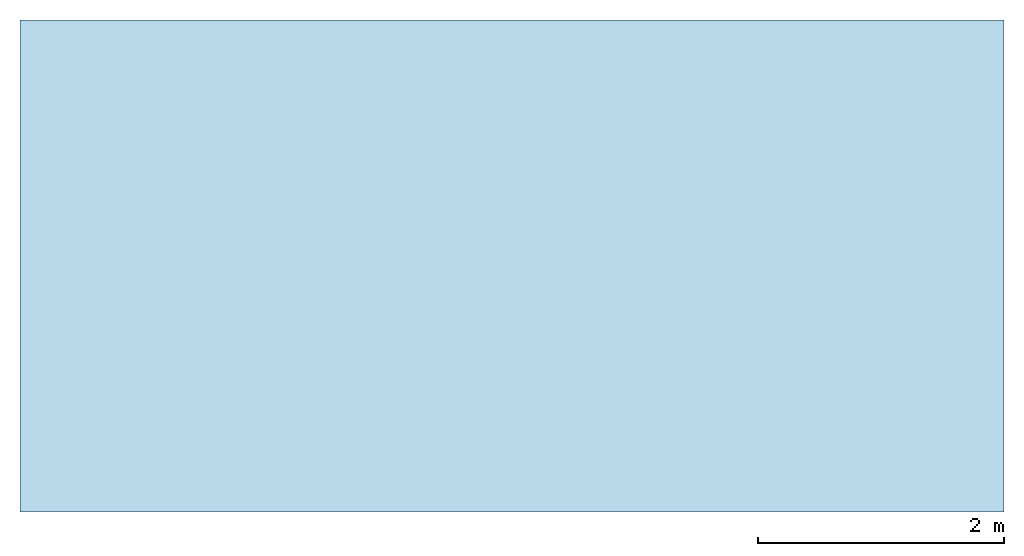
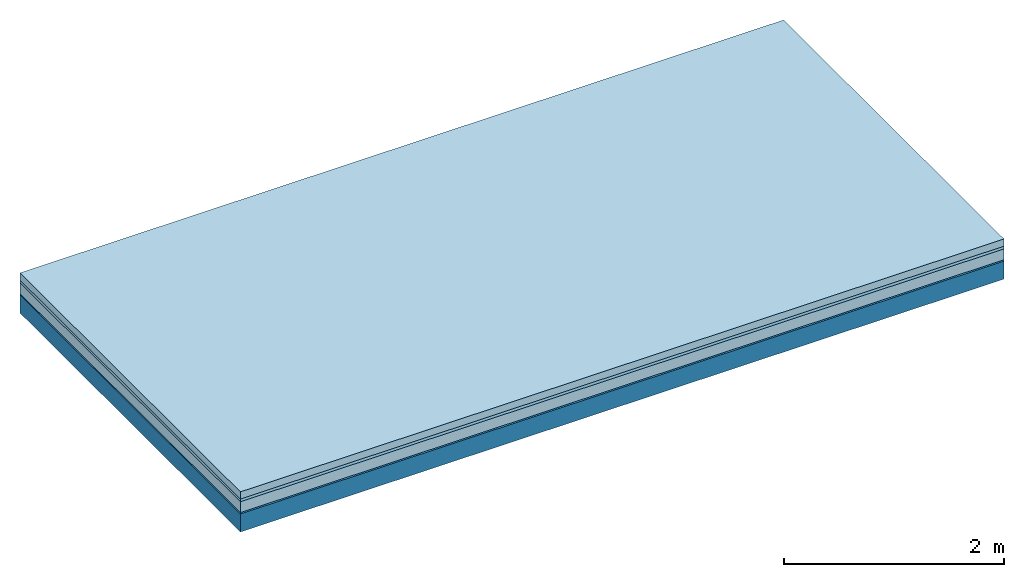
# One storey: 4 plates, 1 member, 1 element without a shape of its own.
"""IFC4 building model written with IfcOpenShell, lengths in metres."""

from ifc_helpers import new_model, si_unit, derived_unit, direction, frame, frame_2d, origin, origin_with_axes, place, context, project, spatial, rectangle, extrude, material, layer, layer_set, type_object, element, aggregate, save


model = new_model("IFC4")

# Units and contexts
plan_context = context("Plan", 3, precision=1e-05, world=origin(), true_north=direction((0.0, 1.0)))
model_context = context("Model", 3, precision=1e-05, world=origin(), true_north=direction((0.0, 1.0)))
ifc_project = project(units=[si_unit("LENGTHUNIT", "METRE"), derived_unit("SOUNDPRESSUREUNIT", [(si_unit("PRESSUREUNIT", "PASCAL", prefix="MICRO"), 0)]), si_unit("ENERGYUNIT", "JOULE", prefix="MEGA"), si_unit("MASSUNIT", "GRAM", prefix="KILO"), derived_unit("THERMALTRANSMITTANCEUNIT", [(si_unit("POWERUNIT", "WATT"), 1), (si_unit("AREAUNIT", "SQUARE_METRE"), -1), (si_unit("THERMODYNAMICTEMPERATUREUNIT", "KELVIN"), -1)]), derived_unit("AREADENSITYUNIT", [(si_unit("MASSUNIT", "GRAM", prefix="KILO"), 1), (si_unit("AREAUNIT", "SQUARE_METRE"), -1)]), derived_unit("USERDEFINED", [(si_unit("ENERGYUNIT", "JOULE", prefix="MEGA"), 1), (si_unit("AREAUNIT", "SQUARE_METRE"), -1)])], contexts=[plan_context, model_context])

# Site, building, storey
site = spatial("IfcSite", under=ifc_project)
building_placement = place(None, origin())
building = spatial("IfcBuilding", under=site, at=building_placement)
storey_placement = place(building_placement, origin())
storey = spatial("IfcBuildingStorey", under=building, at=storey_placement)

# Slab, member, plates
ifc_material_1 = material(Name="Cement screed", Category="04.006")
ifc_layer_1 = layer(ifc_material_1, 0.08, Name="On-material")
ifc_material_2 = material()
ifc_layer_2 = layer(ifc_material_2, 0.03, Name="Impact sound insulation")
ifc_material_3 = material(Category="03.011")
ifc_layer_3 = layer(ifc_material_3, 0.12, Name="on Supporting structure")
ifc_material_4 = material(Category="03.007")
ifc_layer_4 = layer(ifc_material_4, 0.015, Name="Sub-floor")
ifc_material_5 = material(Name="of the art")
ifc_layer_5 = layer(ifc_material_5, 0.0, Name="Bond")
ifc_layer_6 = layer(None, 0.2, Name="Supporting structure")
ifc_layer_set = layer_set([ifc_layer_1, ifc_layer_2, ifc_layer_3, ifc_layer_4, ifc_layer_5, ifc_layer_6])
slab_type = type_object("IfcSlabType", Name="A1103", PredefinedType="NOTDEFINED", material=ifc_layer_set)
slab_placement = place(None, frame((0.0, 0.0, 0.0), z_axis=(0.0, 0.0, -1.0), x_axis=(1.0, 0.0, 0.0)))
slab = element("IfcSlab", 1, at=slab_placement, inside=storey, type_object=slab_type, material=ifc_layer_set, Name="Slab #1")
ifc_material_6 = material()
member_placement = place(slab_placement, origin())
member = element("IfcMember", 2, at=member_placement, material=ifc_material_6, Name="Supporting structure", context=plan_context, shape_type="SweptSolid", body=[
    extrude(rectangle(XDim=1.0, YDim=0.2, at=frame_2d((0.5, 0.1), x_axis=(1.0, 0.0))), frame((0.0, 4.0, 0.245), z_axis=(0.0, -1.0, 0.0), x_axis=(1.0, 0.0, 0.0)), (0.0, 0.0, 1.0), 4.0),
    extrude(rectangle(XDim=1.0, YDim=0.2, at=frame_2d((0.5, 0.1), x_axis=(1.0, 0.0))), frame((1.0, 4.0, 0.245), z_axis=(0.0, -1.0, 0.0), x_axis=(1.0, 0.0, 0.0)), (0.0, 0.0, 1.0), 4.0),
    extrude(rectangle(XDim=1.0, YDim=0.2, at=frame_2d((0.5, 0.1), x_axis=(1.0, 0.0))), frame((2.0, 4.0, 0.245), z_axis=(0.0, -1.0, 0.0), x_axis=(1.0, 0.0, 0.0)), (0.0, 0.0, 1.0), 4.0),
    extrude(rectangle(XDim=1.0, YDim=0.2, at=frame_2d((0.5, 0.1), x_axis=(1.0, 0.0))), frame((3.0, 4.0, 0.245), z_axis=(0.0, -1.0, 0.0), x_axis=(1.0, 0.0, 0.0)), (0.0, 0.0, 1.0), 4.0),
    extrude(rectangle(XDim=1.0, YDim=0.2, at=frame_2d((0.5, 0.1), x_axis=(1.0, 0.0))), frame((4.0, 4.0, 0.245), z_axis=(0.0, -1.0, 0.0), x_axis=(1.0, 0.0, 0.0)), (0.0, 0.0, 1.0), 4.0),
    extrude(rectangle(XDim=1.0, YDim=0.2, at=frame_2d((0.5, 0.1), x_axis=(1.0, 0.0))), frame((5.0, 4.0, 0.245), z_axis=(0.0, -1.0, 0.0), x_axis=(1.0, 0.0, 0.0)), (0.0, 0.0, 1.0), 4.0),
    extrude(rectangle(XDim=1.0, YDim=0.2, at=frame_2d((0.5, 0.1), x_axis=(1.0, 0.0))), frame((6.0, 4.0, 0.245), z_axis=(0.0, -1.0, 0.0), x_axis=(1.0, 0.0, 0.0)), (0.0, 0.0, 1.0), 4.0),
    extrude(rectangle(XDim=1.0, YDim=0.2, at=frame_2d((0.5, 0.1), x_axis=(1.0, 0.0))), frame((7.0, 4.0, 0.245), z_axis=(0.0, -1.0, 0.0), x_axis=(1.0, 0.0, 0.0)), (0.0, 0.0, 1.0), 4.0),
])
plate_1_placement = place(slab_placement, origin())
plate_1 = element("IfcPlate", 3, at=plate_1_placement, material=ifc_material_1, Name="On-material", context=plan_context, shape_type="SweptSolid", body=[
    extrude(rectangle(XDim=8.0, YDim=4.0, at=frame_2d((4.0, 2.0), x_axis=(1.0, 0.0))), origin_with_axes(), (0.0, 0.0, 1.0), 0.08),
])
plate_2_placement = place(slab_placement, origin())
plate_2 = element("IfcPlate", 4, at=plate_2_placement, material=ifc_material_2, Name="Impact sound insulation", context=plan_context, shape_type="SweptSolid", body=[
    extrude(rectangle(XDim=8.0, YDim=4.0, at=frame_2d((4.0, 2.0), x_axis=(1.0, 0.0))), frame((0.0, 0.0, 0.08), z_axis=(0.0, 0.0, 1.0), x_axis=(1.0, 0.0, 0.0)), (0.0, 0.0, 1.0), 0.03),
])
plate_3_placement = place(slab_placement, origin())
plate_3 = element("IfcPlate", 5, at=plate_3_placement, material=ifc_material_3, Name="on Supporting structure", context=plan_context, shape_type="SweptSolid", body=[
    extrude(rectangle(XDim=8.0, YDim=4.0, at=frame_2d((4.0, 2.0), x_axis=(1.0, 0.0))), frame((0.0, 0.0, 0.11), z_axis=(0.0, 0.0, 1.0), x_axis=(1.0, 0.0, 0.0)), (0.0, 0.0, 1.0), 0.12),
])
plate_4_placement = place(slab_placement, origin())
plate_4 = element("IfcPlate", 6, at=plate_4_placement, material=ifc_material_4, Name="Sub-floor", context=plan_context, shape_type="SweptSolid", body=[
    extrude(rectangle(XDim=8.0, YDim=4.0, at=frame_2d((4.0, 2.0), x_axis=(1.0, 0.0))), frame((0.0, 0.0, 0.23), z_axis=(0.0, 0.0, 1.0), x_axis=(1.0, 0.0, 0.0)), (0.0, 0.0, 1.0), 0.015),
])
aggregate(slab, [plate_1, plate_2, plate_3, plate_4, member])

save(model, "model.ifc")
